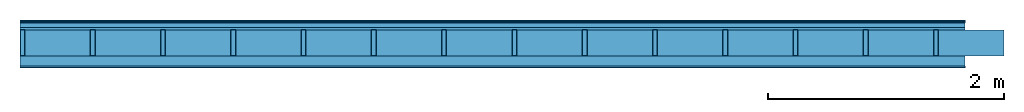
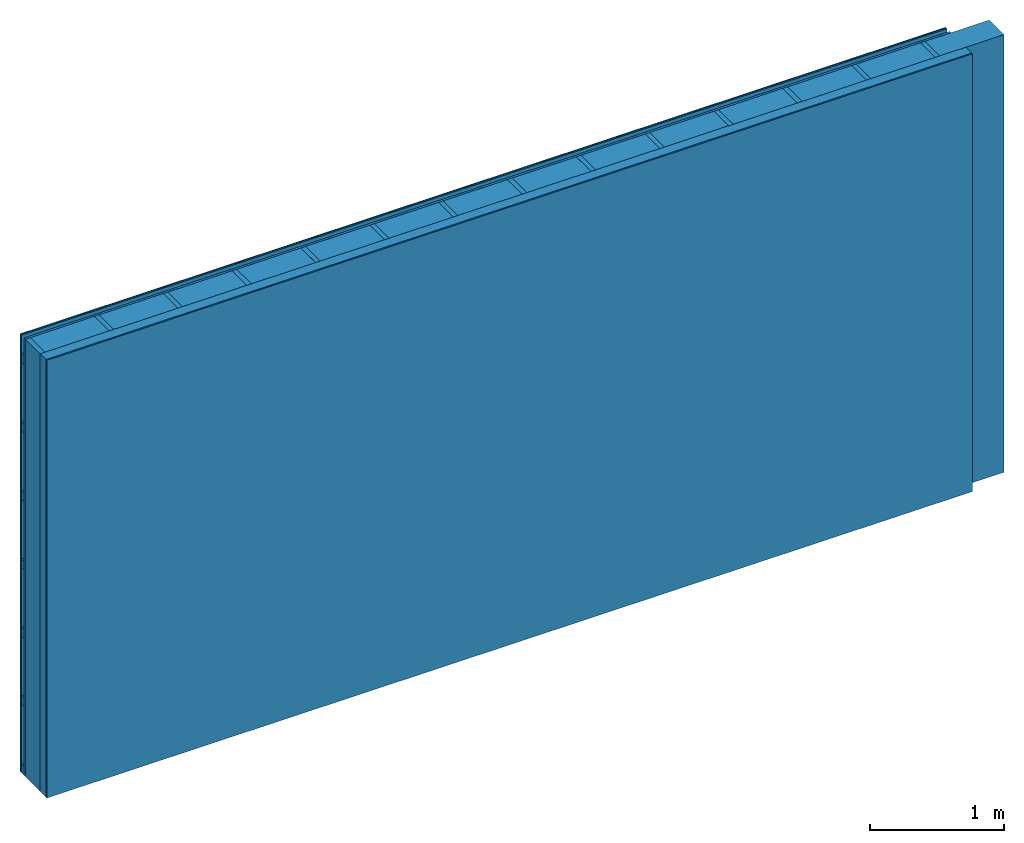
# One storey: 5 plates, 3 members, 1 element without a shape of its own.
"""IFC4 building model written with IfcOpenShell, lengths in metres."""

from ifc_helpers import new_model, si_unit, derived_unit, direction, frame, frame_2d, origin, origin_with_axes, place, context, project, spatial, rectangle, extrude, material, layer, layer_set, type_object, element, aggregate, save


model = new_model("IFC4")

# Units and contexts
plan_context = context("Plan", 3, precision=1e-05, world=origin(), true_north=direction((0.0, 1.0)))
model_context = context("Model", 3, precision=1e-05, world=origin(), true_north=direction((0.0, 1.0)))
ifc_project = project(units=[si_unit("LENGTHUNIT", "METRE"), derived_unit("SOUNDPRESSUREUNIT", [(si_unit("PRESSUREUNIT", "PASCAL", prefix="MICRO"), 0)]), si_unit("ENERGYUNIT", "JOULE", prefix="MEGA"), si_unit("MASSUNIT", "GRAM", prefix="KILO"), derived_unit("THERMALTRANSMITTANCEUNIT", [(si_unit("POWERUNIT", "WATT"), 1), (si_unit("AREAUNIT", "SQUARE_METRE"), -1), (si_unit("THERMODYNAMICTEMPERATUREUNIT", "KELVIN"), -1)]), derived_unit("AREADENSITYUNIT", [(si_unit("MASSUNIT", "GRAM", prefix="KILO"), 1), (si_unit("AREAUNIT", "SQUARE_METRE"), -1)]), derived_unit("USERDEFINED", [(si_unit("ENERGYUNIT", "JOULE", prefix="MEGA"), 1), (si_unit("AREAUNIT", "SQUARE_METRE"), -1)])], contexts=[plan_context, model_context])

# Site, building, storey
site = spatial("IfcSite", under=ifc_project)
building_placement = place(None, origin())
building = spatial("IfcBuilding", under=site, at=building_placement)
storey_placement = place(building_placement, origin())
storey = spatial("IfcBuildingStorey", under=building, at=storey_placement)

# Wall, members, plates
ifc_material_1 = material(Category="04.011")
ifc_layer_1 = layer(ifc_material_1, 0.01, Name="Surface 1")
ifc_material_2 = material(Name="mineral, cement-based building board", Category="03.003")
ifc_layer_2 = layer(ifc_material_2, 0.013, Name="Cover 1st layer")
ifc_layer_3 = layer(None, 0.04, Name="Battens / profiles (ventilation)")
ifc_material_3 = material(Category="10.009")
ifc_layer_4 = layer(ifc_material_3, 0.02, Name="outside 1st layer")
ifc_material_4 = material(Name="of the art")
ifc_layer_5 = layer(ifc_material_4, 0.0, Name="Bond")
ifc_layer_6 = layer(None, 0.22, Name="Support")
ifc_layer_7 = layer(ifc_material_4, 0.0, Name="Bond")
ifc_material_5 = material(Name="Solid timber panel")
ifc_layer_8 = layer(ifc_material_5, 0.087, Name="1st layer")
ifc_material_6 = material(Name="Plasterboard type A", Category="03.008")
ifc_layer_9 = layer(ifc_material_6, 0.0125, Name="Covering 1st layer")
ifc_material_7 = material(Name="joints", Category="04.017")
ifc_layer_10 = layer(ifc_material_7, 0.0, Name="Surface")
ifc_layer_set = layer_set([ifc_layer_1, ifc_layer_2, ifc_layer_3, ifc_layer_4, ifc_layer_5, ifc_layer_6, ifc_layer_7, ifc_layer_8, ifc_layer_9, ifc_layer_10])
wall_type = type_object("IfcWallType", Name="D0976", PredefinedType="NOTDEFINED", material=ifc_layer_set)
wall_placement = place(None, frame((0.0, 0.0, 0.0), z_axis=(0.0, -1.0, 0.0), x_axis=(1.0, 0.0, 0.0)))
wall = element("IfcWall", 1, at=wall_placement, inside=storey, type_object=wall_type, material=ifc_layer_set, Name="Wall #1")
ifc_material_8 = material()
member_1_placement = place(wall_placement, origin())
member_1 = element("IfcMember", 2, at=member_1_placement, material=ifc_material_8, Name="Battens / profiles (ventilation)", context=plan_context, shape_type="SweptSolid", body=[
    extrude(rectangle(XDim=0.08, YDim=0.04, at=frame_2d((0.04, 0.02), x_axis=(1.0, 0.0))), frame((0.0, 0.0, 0.023), z_axis=(1.0, 0.0, 0.0), x_axis=(0.0, 1.0, 0.0)), (0.0, 0.0, 1.0), 8.0),
    extrude(rectangle(XDim=0.08, YDim=0.04, at=frame_2d((0.04, 0.02), x_axis=(1.0, 0.0))), frame((0.0, 0.625, 0.023), z_axis=(1.0, 0.0, 0.0), x_axis=(0.0, 1.0, 0.0)), (0.0, 0.0, 1.0), 8.0),
    extrude(rectangle(XDim=0.08, YDim=0.04, at=frame_2d((0.04, 0.02), x_axis=(1.0, 0.0))), frame((0.0, 1.25, 0.023), z_axis=(1.0, 0.0, 0.0), x_axis=(0.0, 1.0, 0.0)), (0.0, 0.0, 1.0), 8.0),
    extrude(rectangle(XDim=0.08, YDim=0.04, at=frame_2d((0.04, 0.02), x_axis=(1.0, 0.0))), frame((0.0, 1.875, 0.023), z_axis=(1.0, 0.0, 0.0), x_axis=(0.0, 1.0, 0.0)), (0.0, 0.0, 1.0), 8.0),
    extrude(rectangle(XDim=0.08, YDim=0.04, at=frame_2d((0.04, 0.02), x_axis=(1.0, 0.0))), frame((0.0, 2.5, 0.023), z_axis=(1.0, 0.0, 0.0), x_axis=(0.0, 1.0, 0.0)), (0.0, 0.0, 1.0), 8.0),
    extrude(rectangle(XDim=0.08, YDim=0.04, at=frame_2d((0.04, 0.02), x_axis=(1.0, 0.0))), frame((0.0, 3.125, 0.023), z_axis=(1.0, 0.0, 0.0), x_axis=(0.0, 1.0, 0.0)), (0.0, 0.0, 1.0), 8.0),
    extrude(rectangle(XDim=0.08, YDim=0.04, at=frame_2d((0.04, 0.02), x_axis=(1.0, 0.0))), frame((0.0, 3.75, 0.023), z_axis=(1.0, 0.0, 0.0), x_axis=(0.0, 1.0, 0.0)), (0.0, 0.0, 1.0), 8.0),
])
ifc_material_9 = material()
member_2_placement = place(wall_placement, origin())
member_2 = element("IfcMember", 3, at=member_2_placement, material=ifc_material_9, Name="Support", context=plan_context, shape_type="SweptSolid", body=[
    extrude(rectangle(XDim=0.04, YDim=0.22, at=frame_2d((0.02, 0.11), x_axis=(1.0, 0.0))), frame((0.0, 4.0, 0.083), z_axis=(0.0, -1.0, 0.0), x_axis=(1.0, 0.0, 0.0)), (0.0, 0.0, 1.0), 4.0),
    extrude(rectangle(XDim=0.04, YDim=0.22, at=frame_2d((0.02, 0.11), x_axis=(1.0, 0.0))), frame((0.595, 4.0, 0.083), z_axis=(0.0, -1.0, 0.0), x_axis=(1.0, 0.0, 0.0)), (0.0, 0.0, 1.0), 4.0),
    extrude(rectangle(XDim=0.04, YDim=0.22, at=frame_2d((0.02, 0.11), x_axis=(1.0, 0.0))), frame((1.19, 4.0, 0.083), z_axis=(0.0, -1.0, 0.0), x_axis=(1.0, 0.0, 0.0)), (0.0, 0.0, 1.0), 4.0),
    extrude(rectangle(XDim=0.04, YDim=0.22, at=frame_2d((0.02, 0.11), x_axis=(1.0, 0.0))), frame((1.785, 4.0, 0.083), z_axis=(0.0, -1.0, 0.0), x_axis=(1.0, 0.0, 0.0)), (0.0, 0.0, 1.0), 4.0),
    extrude(rectangle(XDim=0.04, YDim=0.22, at=frame_2d((0.02, 0.11), x_axis=(1.0, 0.0))), frame((2.38, 4.0, 0.083), z_axis=(0.0, -1.0, 0.0), x_axis=(1.0, 0.0, 0.0)), (0.0, 0.0, 1.0), 4.0),
    extrude(rectangle(XDim=0.04, YDim=0.22, at=frame_2d((0.02, 0.11), x_axis=(1.0, 0.0))), frame((2.975, 4.0, 0.083), z_axis=(0.0, -1.0, 0.0), x_axis=(1.0, 0.0, 0.0)), (0.0, 0.0, 1.0), 4.0),
    extrude(rectangle(XDim=0.04, YDim=0.22, at=frame_2d((0.02, 0.11), x_axis=(1.0, 0.0))), frame((3.57, 4.0, 0.083), z_axis=(0.0, -1.0, 0.0), x_axis=(1.0, 0.0, 0.0)), (0.0, 0.0, 1.0), 4.0),
    extrude(rectangle(XDim=0.04, YDim=0.22, at=frame_2d((0.02, 0.11), x_axis=(1.0, 0.0))), frame((4.165, 4.0, 0.083), z_axis=(0.0, -1.0, 0.0), x_axis=(1.0, 0.0, 0.0)), (0.0, 0.0, 1.0), 4.0),
    extrude(rectangle(XDim=0.04, YDim=0.22, at=frame_2d((0.02, 0.11), x_axis=(1.0, 0.0))), frame((4.76, 4.0, 0.083), z_axis=(0.0, -1.0, 0.0), x_axis=(1.0, 0.0, 0.0)), (0.0, 0.0, 1.0), 4.0),
    extrude(rectangle(XDim=0.04, YDim=0.22, at=frame_2d((0.02, 0.11), x_axis=(1.0, 0.0))), frame((5.355, 4.0, 0.083), z_axis=(0.0, -1.0, 0.0), x_axis=(1.0, 0.0, 0.0)), (0.0, 0.0, 1.0), 4.0),
    extrude(rectangle(XDim=0.04, YDim=0.22, at=frame_2d((0.02, 0.11), x_axis=(1.0, 0.0))), frame((5.95, 4.0, 0.083), z_axis=(0.0, -1.0, 0.0), x_axis=(1.0, 0.0, 0.0)), (0.0, 0.0, 1.0), 4.0),
    extrude(rectangle(XDim=0.04, YDim=0.22, at=frame_2d((0.02, 0.11), x_axis=(1.0, 0.0))), frame((6.545, 4.0, 0.083), z_axis=(0.0, -1.0, 0.0), x_axis=(1.0, 0.0, 0.0)), (0.0, 0.0, 1.0), 4.0),
    extrude(rectangle(XDim=0.04, YDim=0.22, at=frame_2d((0.02, 0.11), x_axis=(1.0, 0.0))), frame((7.14, 4.0, 0.083), z_axis=(0.0, -1.0, 0.0), x_axis=(1.0, 0.0, 0.0)), (0.0, 0.0, 1.0), 4.0),
    extrude(rectangle(XDim=0.04, YDim=0.22, at=frame_2d((0.02, 0.11), x_axis=(1.0, 0.0))), frame((7.735, 4.0, 0.083), z_axis=(0.0, -1.0, 0.0), x_axis=(1.0, 0.0, 0.0)), (0.0, 0.0, 1.0), 4.0),
])
ifc_material_10 = material()
member_3_placement = place(wall_placement, origin())
member_3 = element("IfcMember", 4, at=member_3_placement, material=ifc_material_10, Name="Cavity", context=plan_context, shape_type="SweptSolid", body=[
    extrude(rectangle(XDim=0.555, YDim=0.22, at=frame_2d((0.2775, 0.11), x_axis=(1.0, 0.0))), frame((0.04, 4.0, 0.083), z_axis=(0.0, -1.0, 0.0), x_axis=(1.0, 0.0, 0.0)), (0.0, 0.0, 1.0), 4.0),
    extrude(rectangle(XDim=0.555, YDim=0.22, at=frame_2d((0.2775, 0.11), x_axis=(1.0, 0.0))), frame((0.635, 4.0, 0.083), z_axis=(0.0, -1.0, 0.0), x_axis=(1.0, 0.0, 0.0)), (0.0, 0.0, 1.0), 4.0),
    extrude(rectangle(XDim=0.555, YDim=0.22, at=frame_2d((0.2775, 0.11), x_axis=(1.0, 0.0))), frame((1.23, 4.0, 0.083), z_axis=(0.0, -1.0, 0.0), x_axis=(1.0, 0.0, 0.0)), (0.0, 0.0, 1.0), 4.0),
    extrude(rectangle(XDim=0.555, YDim=0.22, at=frame_2d((0.2775, 0.11), x_axis=(1.0, 0.0))), frame((1.825, 4.0, 0.083), z_axis=(0.0, -1.0, 0.0), x_axis=(1.0, 0.0, 0.0)), (0.0, 0.0, 1.0), 4.0),
    extrude(rectangle(XDim=0.555, YDim=0.22, at=frame_2d((0.2775, 0.11), x_axis=(1.0, 0.0))), frame((2.42, 4.0, 0.083), z_axis=(0.0, -1.0, 0.0), x_axis=(1.0, 0.0, 0.0)), (0.0, 0.0, 1.0), 4.0),
    extrude(rectangle(XDim=0.555, YDim=0.22, at=frame_2d((0.2775, 0.11), x_axis=(1.0, 0.0))), frame((3.015, 4.0, 0.083), z_axis=(0.0, -1.0, 0.0), x_axis=(1.0, 0.0, 0.0)), (0.0, 0.0, 1.0), 4.0),
    extrude(rectangle(XDim=0.555, YDim=0.22, at=frame_2d((0.2775, 0.11), x_axis=(1.0, 0.0))), frame((3.61, 4.0, 0.083), z_axis=(0.0, -1.0, 0.0), x_axis=(1.0, 0.0, 0.0)), (0.0, 0.0, 1.0), 4.0),
    extrude(rectangle(XDim=0.555, YDim=0.22, at=frame_2d((0.2775, 0.11), x_axis=(1.0, 0.0))), frame((4.205, 4.0, 0.083), z_axis=(0.0, -1.0, 0.0), x_axis=(1.0, 0.0, 0.0)), (0.0, 0.0, 1.0), 4.0),
    extrude(rectangle(XDim=0.555, YDim=0.22, at=frame_2d((0.2775, 0.11), x_axis=(1.0, 0.0))), frame((4.8, 4.0, 0.083), z_axis=(0.0, -1.0, 0.0), x_axis=(1.0, 0.0, 0.0)), (0.0, 0.0, 1.0), 4.0),
    extrude(rectangle(XDim=0.555, YDim=0.22, at=frame_2d((0.2775, 0.11), x_axis=(1.0, 0.0))), frame((5.395, 4.0, 0.083), z_axis=(0.0, -1.0, 0.0), x_axis=(1.0, 0.0, 0.0)), (0.0, 0.0, 1.0), 4.0),
    extrude(rectangle(XDim=0.555, YDim=0.22, at=frame_2d((0.2775, 0.11), x_axis=(1.0, 0.0))), frame((5.99, 4.0, 0.083), z_axis=(0.0, -1.0, 0.0), x_axis=(1.0, 0.0, 0.0)), (0.0, 0.0, 1.0), 4.0),
    extrude(rectangle(XDim=0.555, YDim=0.22, at=frame_2d((0.2775, 0.11), x_axis=(1.0, 0.0))), frame((6.585, 4.0, 0.083), z_axis=(0.0, -1.0, 0.0), x_axis=(1.0, 0.0, 0.0)), (0.0, 0.0, 1.0), 4.0),
    extrude(rectangle(XDim=0.555, YDim=0.22, at=frame_2d((0.2775, 0.11), x_axis=(1.0, 0.0))), frame((7.18, 4.0, 0.083), z_axis=(0.0, -1.0, 0.0), x_axis=(1.0, 0.0, 0.0)), (0.0, 0.0, 1.0), 4.0),
    extrude(rectangle(XDim=0.555, YDim=0.22, at=frame_2d((0.2775, 0.11), x_axis=(1.0, 0.0))), frame((7.775, 4.0, 0.083), z_axis=(0.0, -1.0, 0.0), x_axis=(1.0, 0.0, 0.0)), (0.0, 0.0, 1.0), 4.0),
])
plate_1_placement = place(wall_placement, origin())
plate_1 = element("IfcPlate", 5, at=plate_1_placement, material=ifc_material_1, Name="Surface 1", context=plan_context, shape_type="SweptSolid", body=[
    extrude(rectangle(XDim=8.0, YDim=4.0, at=frame_2d((4.0, 2.0), x_axis=(1.0, 0.0))), origin_with_axes(), (0.0, 0.0, 1.0), 0.01),
])
plate_2_placement = place(wall_placement, origin())
plate_2 = element("IfcPlate", 6, at=plate_2_placement, material=ifc_material_2, Name="Cover 1st layer", context=plan_context, shape_type="SweptSolid", body=[
    extrude(rectangle(XDim=8.0, YDim=4.0, at=frame_2d((4.0, 2.0), x_axis=(1.0, 0.0))), frame((0.0, 0.0, 0.01), z_axis=(0.0, 0.0, 1.0), x_axis=(1.0, 0.0, 0.0)), (0.0, 0.0, 1.0), 0.013),
])
plate_3_placement = place(wall_placement, origin())
plate_3 = element("IfcPlate", 7, at=plate_3_placement, material=ifc_material_3, Name="outside 1st layer", context=plan_context, shape_type="SweptSolid", body=[
    extrude(rectangle(XDim=8.0, YDim=4.0, at=frame_2d((4.0, 2.0), x_axis=(1.0, 0.0))), frame((0.0, 0.0, 0.063), z_axis=(0.0, 0.0, 1.0), x_axis=(1.0, 0.0, 0.0)), (0.0, 0.0, 1.0), 0.02),
])
plate_4_placement = place(wall_placement, origin())
plate_4 = element("IfcPlate", 8, at=plate_4_placement, material=ifc_material_5, Name="1st layer", context=plan_context, shape_type="SweptSolid", body=[
    extrude(rectangle(XDim=8.0, YDim=4.0, at=frame_2d((4.0, 2.0), x_axis=(1.0, 0.0))), frame((0.0, 0.0, 0.303), z_axis=(0.0, 0.0, 1.0), x_axis=(1.0, 0.0, 0.0)), (0.0, 0.0, 1.0), 0.087),
])
plate_5_placement = place(wall_placement, origin())
plate_5 = element("IfcPlate", 9, at=plate_5_placement, material=ifc_material_6, Name="Covering 1st layer", context=plan_context, shape_type="SweptSolid", body=[
    extrude(rectangle(XDim=8.0, YDim=4.0, at=frame_2d((4.0, 2.0), x_axis=(1.0, 0.0))), frame((0.0, 0.0, 0.39), z_axis=(0.0, 0.0, 1.0), x_axis=(1.0, 0.0, 0.0)), (0.0, 0.0, 1.0), 0.0125),
])
aggregate(wall, [plate_1, plate_2, member_1, plate_3, member_2, member_3, plate_4, plate_5])

save(model, "model.ifc")
